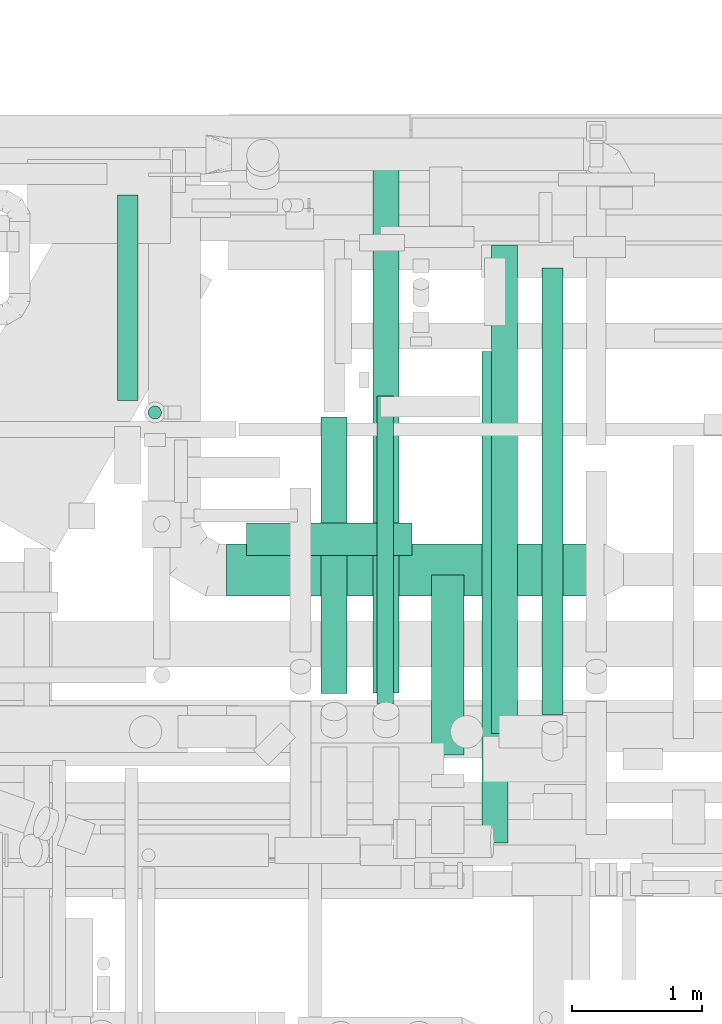
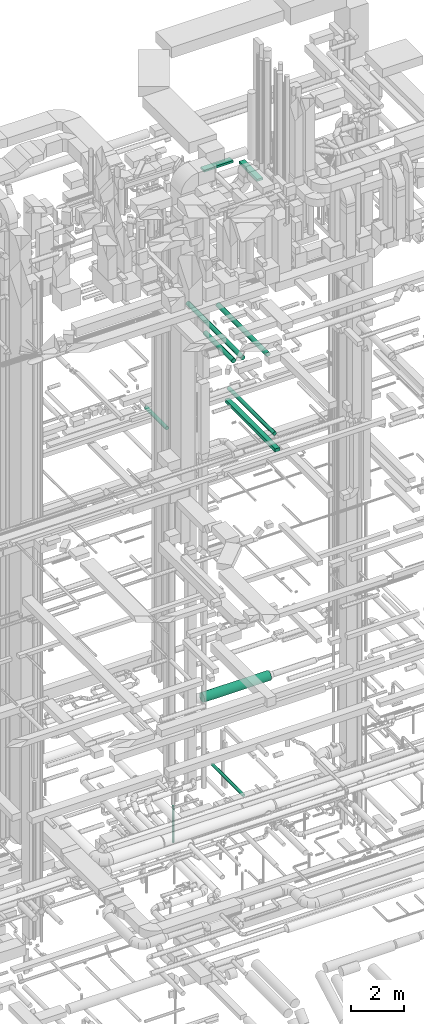
# One storey, part 76 of 337: 11 flow segments.
"""IFC2X3 building model written with IfcOpenShell, lengths in millimetres."""

from ifc_helpers import new_model, entity, si_unit, converted_unit, derived_unit, direction, frame, origin, origin_2d_with_axis, place, context, subcontext, project, spatial, rectangle, circle, extrude, type_object, element, save


model = new_model("IFC2X3")

# Units and contexts
model_context = context("Model", 3, precision=0.01, world=origin(), true_north=direction((6.12303176911189e-17, 1.0)))
body_context = subcontext(model_context, "Body", "Model", "MODEL_VIEW")
ifc_project = project(units=[si_unit("LENGTHUNIT", "METRE", prefix="MILLI"), si_unit("AREAUNIT", "SQUARE_METRE"), si_unit("VOLUMEUNIT", "CUBIC_METRE"), converted_unit("PLANEANGLEUNIT", "DEGREE", entity("IfcRatioMeasure", 0.0174532925199433), si_unit("PLANEANGLEUNIT", "RADIAN"), dimensions=[0, 0, 0, 0, 0, 0, 0]), si_unit("MASSUNIT", "GRAM", prefix="KILO"), derived_unit("MASSDENSITYUNIT", [(si_unit("MASSUNIT", "GRAM", prefix="KILO"), 1), (si_unit("LENGTHUNIT", "METRE"), -3)]), derived_unit("MOMENTOFINERTIAUNIT", [(si_unit("LENGTHUNIT", "METRE"), 4)]), si_unit("TIMEUNIT", "SECOND"), si_unit("FREQUENCYUNIT", "HERTZ"), si_unit("THERMODYNAMICTEMPERATUREUNIT", "DEGREE_CELSIUS"), derived_unit("THERMALTRANSMITTANCEUNIT", [(si_unit("MASSUNIT", "GRAM", prefix="KILO"), 1), (si_unit("THERMODYNAMICTEMPERATUREUNIT", "KELVIN"), -1), (si_unit("TIMEUNIT", "SECOND"), -3)]), derived_unit("VOLUMETRICFLOWRATEUNIT", [(si_unit("LENGTHUNIT", "METRE"), 3), (si_unit("TIMEUNIT", "SECOND"), -1)]), derived_unit("MASSFLOWRATEUNIT", [(si_unit("MASSUNIT", "GRAM", prefix="KILO"), 1), (si_unit("TIMEUNIT", "SECOND"), -1)]), derived_unit("ROTATIONALFREQUENCYUNIT", [(si_unit("TIMEUNIT", "SECOND"), -1)]), si_unit("ELECTRICCURRENTUNIT", "AMPERE"), si_unit("ELECTRICVOLTAGEUNIT", "VOLT"), si_unit("POWERUNIT", "WATT"), si_unit("FORCEUNIT", "NEWTON", prefix="KILO"), si_unit("ILLUMINANCEUNIT", "LUX"), si_unit("LUMINOUSFLUXUNIT", "LUMEN"), si_unit("LUMINOUSINTENSITYUNIT", "CANDELA"), derived_unit("USERDEFINED", [(si_unit("MASSUNIT", "GRAM", prefix="KILO"), -1), (si_unit("LENGTHUNIT", "METRE"), -2), (si_unit("TIMEUNIT", "SECOND"), 3), (si_unit("LUMINOUSFLUXUNIT", "LUMEN"), 1)]), derived_unit("LINEARVELOCITYUNIT", [(si_unit("LENGTHUNIT", "METRE"), 1), (si_unit("TIMEUNIT", "SECOND"), -1)]), si_unit("PRESSUREUNIT", "PASCAL"), derived_unit("USERDEFINED", [(si_unit("LENGTHUNIT", "METRE"), -2), (si_unit("MASSUNIT", "GRAM", prefix="KILO"), 1), (si_unit("TIMEUNIT", "SECOND"), -2)]), derived_unit("LINEARFORCEUNIT", [(si_unit("MASSUNIT", "GRAM", prefix="KILO"), 1), (si_unit("LENGTHUNIT", "METRE"), 1), (si_unit("TIMEUNIT", "SECOND"), -2), (si_unit("LENGTHUNIT", "METRE"), -1)]), derived_unit("PLANARFORCEUNIT", [(si_unit("MASSUNIT", "GRAM", prefix="KILO"), 1), (si_unit("LENGTHUNIT", "METRE"), 1), (si_unit("TIMEUNIT", "SECOND"), -2), (si_unit("LENGTHUNIT", "METRE"), -2)])], contexts=[model_context])

# Site, building, storey
site_placement = place(None, origin())
site = spatial("IfcSite", under=ifc_project, at=site_placement, CompositionType="ELEMENT")
building_placement = place(site_placement, origin())
building = spatial("IfcBuilding", under=site, at=building_placement, CompositionType="ELEMENT")
storey_placement = place(building_placement, origin())
storey = spatial("IfcBuildingStorey", under=building, at=storey_placement, CompositionType="ELEMENT", Elevation=0.0)

# Flow segments
duct_segment_type_1 = type_object("IfcDuctSegmentType", PredefinedType="NOTDEFINED")
flow_segment_1_placement = place(storey_placement, frame((57582.59, 14493.91, 15300.0)))
element("IfcFlowSegment", 1, at=flow_segment_1_placement, inside=storey, type_object=duct_segment_type_1, context=body_context, shape_type="SweptSolid", body=[
    extrude(rectangle(XDim=3786.04074498578, YDim=199.999999999998, at=origin_2d_with_axis()), frame((100.0, 1893.02, 0.0), z_axis=(0.0, 0.0, 1.0), x_axis=(0.0, -1.0, 0.0)), (0.0, 0.0, 1.0), 150.000000000001),
])
flow_segment_2_placement = place(storey_placement, frame((55767.89, 16707.02, 27450.0)))
element("IfcFlowSegment", 2, at=flow_segment_2_placement, inside=storey, type_object=duct_segment_type_1, context=body_context, shape_type="SweptSolid", body=[
    extrude(rectangle(XDim=1275.0, YDim=249.999999999999, at=origin_2d_with_axis()), frame((637.5, 125.0, 0.0), z_axis=(0.0, 0.0, 1.0), x_axis=(-1.0, 0.0, 0.0)), (0.0, 0.0, 1.0), 100.000000000003),
])
flow_segment_3_placement = place(storey_placement, frame((57192.89, 15172.02, 27450.0)))
element("IfcFlowSegment", 3, at=flow_segment_3_placement, inside=storey, type_object=duct_segment_type_1, context=body_context, shape_type="SweptSolid", body=[
    extrude(rectangle(XDim=1384.99999999999, YDim=250.000000000004, at=origin_2d_with_axis()), frame((125.0, 692.5, 0.0), z_axis=(0.0, 0.0, 1.0), x_axis=(0.0, -1.0, 0.0)), (0.0, 0.0, 1.0), 100.000000000003),
])
duct_segment_type_2 = type_object("IfcDuctSegmentType", PredefinedType="NOTDEFINED")
flow_segment_4_placement = place(storey_placement, frame((56774.22, 15568.96, -914.1)))
element("IfcFlowSegment", 4, at=flow_segment_4_placement, inside=storey, type_object=duct_segment_type_2, context=body_context, shape_type="SweptSolid", body=[
    extrude(circle(Radius=62.5, at=origin_2d_with_axis()), frame((64.1, 0.0, 64.1), z_axis=(0.0, 1.0, 0.0), x_axis=(-1.0, 0.0, 0.0)), (0.0, 0.0, 1.0), 2365.97546999946),
])
flow_segment_5_placement = place(storey_placement, frame((55012.68, 17757.19, -3730.0)))
element("IfcFlowSegment", 5, at=flow_segment_5_placement, inside=storey, type_object=duct_segment_type_2, context=body_context, shape_type="SweptSolid", body=[
    extrude(circle(Radius=50.0, at=origin_2d_with_axis()), frame((51.6, 51.6, 0.0), z_axis=(0.0, 0.0, 1.0), x_axis=(0.0, 1.0, 0.0)), (0.0, 0.0, 1.0), 1674.99999999999),
])
flow_segment_6_placement = place(storey_placement, frame((57656.55, 15334.34, 19123.4)))
element("IfcFlowSegment", 6, at=flow_segment_6_placement, inside=storey, type_object=duct_segment_type_2, context=body_context, shape_type="SweptSolid", body=[
    extrude(circle(Radius=100.0, at=origin_2d_with_axis()), frame((101.6, 0.0, 101.6), z_axis=(0.0, 1.0, 0.0), x_axis=(-1.0, 0.0, 0.0)), (0.0, 0.0, 1.0), 3765.86311988026),
])
flow_segment_7_placement = place(storey_placement, frame((58045.69, 15481.54, 15288.4)))
element("IfcFlowSegment", 7, at=flow_segment_7_placement, inside=storey, type_object=duct_segment_type_2, context=body_context, shape_type="SweptSolid", body=[
    extrude(circle(Radius=80.0, at=origin_2d_with_axis()), frame((81.6, 0.0, 81.6), z_axis=(0.0, 1.0, 0.0), x_axis=(-1.0, 0.0, 0.0)), (0.0, 0.0, 1.0), 3441.76476251741),
])
flow_segment_8_placement = place(storey_placement, frame((56342.71, 15646.2, 19098.4)))
element("IfcFlowSegment", 8, at=flow_segment_8_placement, inside=storey, type_object=duct_segment_type_2, context=body_context, shape_type="SweptSolid", body=[
    extrude(circle(Radius=100.0, at=origin_2d_with_axis()), frame((101.6, 0.0, 101.6), z_axis=(0.0, 1.0, 0.0), x_axis=(-1.0, 0.0, 0.0)), (0.0, 0.0, 1.0), 2129.31457505077),
])
flow_segment_9_placement = place(storey_placement, frame((56743.44, 15648.36, 19098.4)))
element("IfcFlowSegment", 9, at=flow_segment_9_placement, inside=storey, type_object=duct_segment_type_2, context=body_context, shape_type="SweptSolid", body=[
    extrude(circle(Radius=100.0, at=origin_2d_with_axis()), frame((101.6, 0.0, 101.6), z_axis=(0.0, 1.0, 0.0), x_axis=(-1.0, 0.0, 0.0)), (0.0, 0.0, 1.0), 4127.1572875254),
])
flow_segment_10_placement = place(storey_placement, frame((54772.37, 17900.79, 15218.4)))
element("IfcFlowSegment", 10, at=flow_segment_10_placement, inside=storey, type_object=duct_segment_type_2, context=body_context, shape_type="SweptSolid", body=[
    extrude(circle(Radius=80.0, at=origin_2d_with_axis()), frame((81.6, 0.0, 81.6), z_axis=(0.0, 1.0, 0.0), x_axis=(1.0, 0.0, 0.0)), (0.0, 0.0, 1.0), 1585.0),
])
flow_segment_11_placement = place(storey_placement, frame((55613.74, 16394.65, 3248.4)))
element("IfcFlowSegment", 11, at=flow_segment_11_placement, inside=storey, type_object=duct_segment_type_2, context=body_context, shape_type="SweptSolid", body=[
    extrude(circle(Radius=200.0, at=origin_2d_with_axis()), frame((0.0, 201.6, 201.6), z_axis=(1.0, 0.0, 0.0), x_axis=(0.0, -1.0, 0.0)), (0.0, 0.0, 1.0), 2908.31119788967),
])

save(model, "model.ifc")
